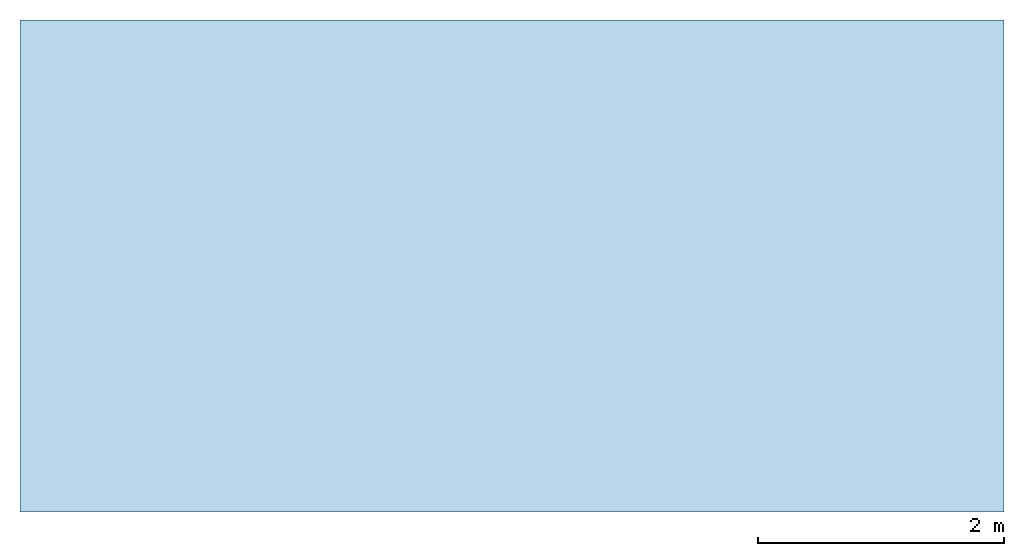
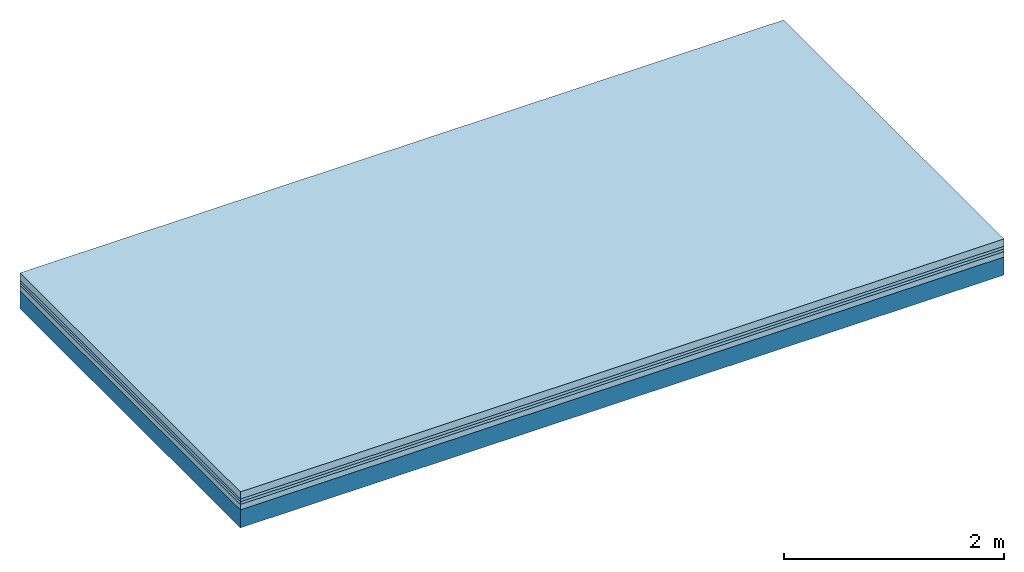
# One storey: 4 plates, 1 member, 1 element without a shape of its own.
"""IFC4 building model written with IfcOpenShell, lengths in metres."""

from ifc_helpers import new_model, si_unit, derived_unit, direction, frame, frame_2d, origin, origin_with_axes, place, context, project, spatial, rectangle, extrude, material, layer, layer_set, type_object, element, aggregate, save


model = new_model("IFC4")

# Units and contexts
plan_context = context("Plan", 3, precision=1e-05, world=origin(), true_north=direction((0.0, 1.0)))
model_context = context("Model", 3, precision=1e-05, world=origin(), true_north=direction((0.0, 1.0)))
ifc_project = project(units=[si_unit("LENGTHUNIT", "METRE"), derived_unit("SOUNDPRESSUREUNIT", [(si_unit("PRESSUREUNIT", "PASCAL", prefix="MICRO"), 0)]), si_unit("ENERGYUNIT", "JOULE", prefix="MEGA"), si_unit("MASSUNIT", "GRAM", prefix="KILO"), derived_unit("THERMALTRANSMITTANCEUNIT", [(si_unit("POWERUNIT", "WATT"), 1), (si_unit("AREAUNIT", "SQUARE_METRE"), -1), (si_unit("THERMODYNAMICTEMPERATUREUNIT", "KELVIN"), -1)]), derived_unit("AREADENSITYUNIT", [(si_unit("MASSUNIT", "GRAM", prefix="KILO"), 1), (si_unit("AREAUNIT", "SQUARE_METRE"), -1)]), derived_unit("USERDEFINED", [(si_unit("ENERGYUNIT", "JOULE", prefix="MEGA"), 1), (si_unit("AREAUNIT", "SQUARE_METRE"), -1)])], contexts=[plan_context, model_context])

# Site, building, storey
site = spatial("IfcSite", under=ifc_project)
building_placement = place(None, origin())
building = spatial("IfcBuilding", under=site, at=building_placement)
storey_placement = place(building_placement, origin())
storey = spatial("IfcBuildingStorey", under=building, at=storey_placement)

# Slab, member, plates
ifc_material_1 = material(Name="Cement screed", Category="04.006")
ifc_layer_1 = layer(ifc_material_1, 0.08, Name="On-material")
ifc_material_2 = material()
ifc_layer_2 = layer(ifc_material_2, 0.03, Name="Impact sound insulation")
ifc_material_3 = material()
ifc_layer_3 = layer(ifc_material_3, 0.03, Name="Additional insulation")
ifc_material_4 = material(Category="03.011")
ifc_layer_4 = layer(ifc_material_4, 0.06, Name="on Supporting structure")
ifc_layer_5 = layer(None, 0.2, Name="Supporting structure")
ifc_layer_set = layer_set([ifc_layer_1, ifc_layer_2, ifc_layer_3, ifc_layer_4, ifc_layer_5])
slab_type = type_object("IfcSlabType", Name="A1087", PredefinedType="NOTDEFINED", material=ifc_layer_set)
slab_placement = place(None, frame((0.0, 0.0, 0.0), z_axis=(0.0, 0.0, -1.0), x_axis=(1.0, 0.0, 0.0)))
slab = element("IfcSlab", 1, at=slab_placement, inside=storey, type_object=slab_type, material=ifc_layer_set, Name="Slab #1")
ifc_material_5 = material()
member_placement = place(slab_placement, origin())
member = element("IfcMember", 2, at=member_placement, material=ifc_material_5, Name="Supporting structure", context=plan_context, shape_type="SweptSolid", body=[
    extrude(rectangle(XDim=1.0, YDim=0.2, at=frame_2d((0.5, 0.1), x_axis=(1.0, 0.0))), frame((0.0, 4.0, 0.2), z_axis=(0.0, -1.0, 0.0), x_axis=(1.0, 0.0, 0.0)), (0.0, 0.0, 1.0), 4.0),
    extrude(rectangle(XDim=1.0, YDim=0.2, at=frame_2d((0.5, 0.1), x_axis=(1.0, 0.0))), frame((1.0, 4.0, 0.2), z_axis=(0.0, -1.0, 0.0), x_axis=(1.0, 0.0, 0.0)), (0.0, 0.0, 1.0), 4.0),
    extrude(rectangle(XDim=1.0, YDim=0.2, at=frame_2d((0.5, 0.1), x_axis=(1.0, 0.0))), frame((2.0, 4.0, 0.2), z_axis=(0.0, -1.0, 0.0), x_axis=(1.0, 0.0, 0.0)), (0.0, 0.0, 1.0), 4.0),
    extrude(rectangle(XDim=1.0, YDim=0.2, at=frame_2d((0.5, 0.1), x_axis=(1.0, 0.0))), frame((3.0, 4.0, 0.2), z_axis=(0.0, -1.0, 0.0), x_axis=(1.0, 0.0, 0.0)), (0.0, 0.0, 1.0), 4.0),
    extrude(rectangle(XDim=1.0, YDim=0.2, at=frame_2d((0.5, 0.1), x_axis=(1.0, 0.0))), frame((4.0, 4.0, 0.2), z_axis=(0.0, -1.0, 0.0), x_axis=(1.0, 0.0, 0.0)), (0.0, 0.0, 1.0), 4.0),
    extrude(rectangle(XDim=1.0, YDim=0.2, at=frame_2d((0.5, 0.1), x_axis=(1.0, 0.0))), frame((5.0, 4.0, 0.2), z_axis=(0.0, -1.0, 0.0), x_axis=(1.0, 0.0, 0.0)), (0.0, 0.0, 1.0), 4.0),
    extrude(rectangle(XDim=1.0, YDim=0.2, at=frame_2d((0.5, 0.1), x_axis=(1.0, 0.0))), frame((6.0, 4.0, 0.2), z_axis=(0.0, -1.0, 0.0), x_axis=(1.0, 0.0, 0.0)), (0.0, 0.0, 1.0), 4.0),
    extrude(rectangle(XDim=1.0, YDim=0.2, at=frame_2d((0.5, 0.1), x_axis=(1.0, 0.0))), frame((7.0, 4.0, 0.2), z_axis=(0.0, -1.0, 0.0), x_axis=(1.0, 0.0, 0.0)), (0.0, 0.0, 1.0), 4.0),
])
plate_1_placement = place(slab_placement, origin())
plate_1 = element("IfcPlate", 3, at=plate_1_placement, material=ifc_material_1, Name="On-material", context=plan_context, shape_type="SweptSolid", body=[
    extrude(rectangle(XDim=8.0, YDim=4.0, at=frame_2d((4.0, 2.0), x_axis=(1.0, 0.0))), origin_with_axes(), (0.0, 0.0, 1.0), 0.08),
])
plate_2_placement = place(slab_placement, origin())
plate_2 = element("IfcPlate", 4, at=plate_2_placement, material=ifc_material_2, Name="Impact sound insulation", context=plan_context, shape_type="SweptSolid", body=[
    extrude(rectangle(XDim=8.0, YDim=4.0, at=frame_2d((4.0, 2.0), x_axis=(1.0, 0.0))), frame((0.0, 0.0, 0.08), z_axis=(0.0, 0.0, 1.0), x_axis=(1.0, 0.0, 0.0)), (0.0, 0.0, 1.0), 0.03),
])
plate_3_placement = place(slab_placement, origin())
plate_3 = element("IfcPlate", 5, at=plate_3_placement, material=ifc_material_3, Name="Additional insulation", context=plan_context, shape_type="SweptSolid", body=[
    extrude(rectangle(XDim=8.0, YDim=4.0, at=frame_2d((4.0, 2.0), x_axis=(1.0, 0.0))), frame((0.0, 0.0, 0.11), z_axis=(0.0, 0.0, 1.0), x_axis=(1.0, 0.0, 0.0)), (0.0, 0.0, 1.0), 0.03),
])
plate_4_placement = place(slab_placement, origin())
plate_4 = element("IfcPlate", 6, at=plate_4_placement, material=ifc_material_4, Name="on Supporting structure", context=plan_context, shape_type="SweptSolid", body=[
    extrude(rectangle(XDim=8.0, YDim=4.0, at=frame_2d((4.0, 2.0), x_axis=(1.0, 0.0))), frame((0.0, 0.0, 0.14), z_axis=(0.0, 0.0, 1.0), x_axis=(1.0, 0.0, 0.0)), (0.0, 0.0, 1.0), 0.06),
])
aggregate(slab, [plate_1, plate_2, plate_3, plate_4, member])

save(model, "model.ifc")
